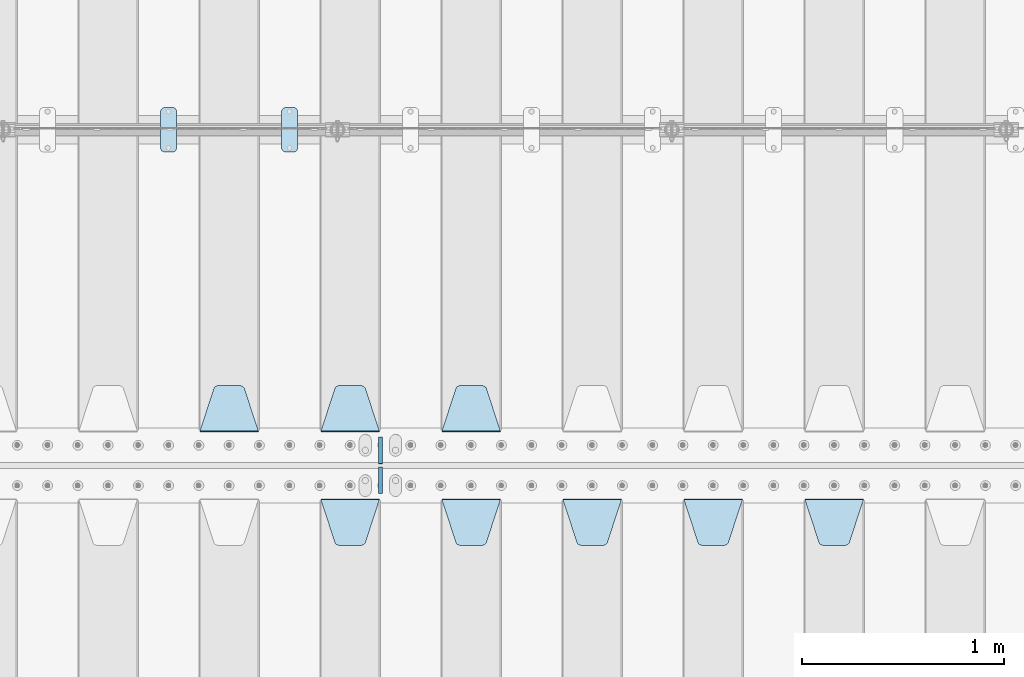
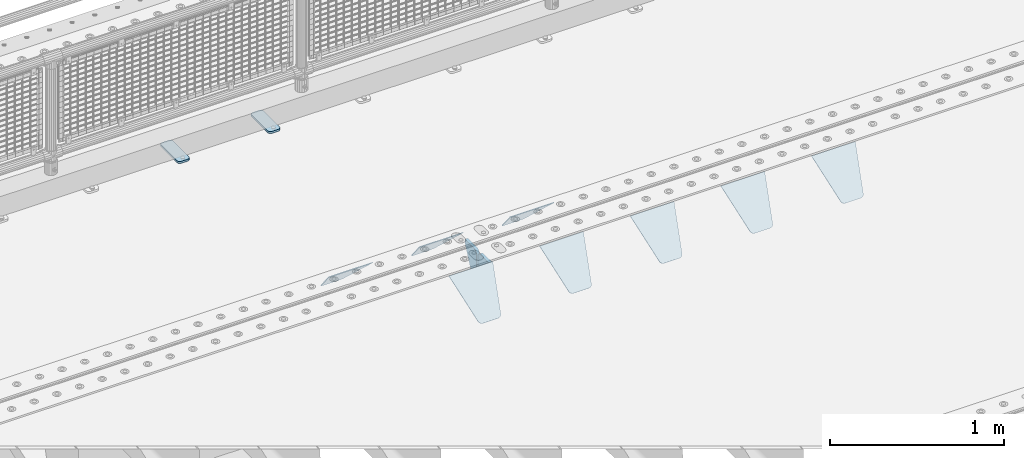
# One storey, part 212 of 240: 12 plates.
"""IFC2X3 building model written with IfcOpenShell, lengths in millimetres."""

from ifc_helpers import new_model, si_unit, frame, origin_with_axes, place, context, subcontext, project, spatial, faceted_brep, material, type_object, element, save


model = new_model("IFC2X3")

# Units and contexts
model_context = context("Model", 3, precision=1e-05, world=origin_with_axes())
body_context = subcontext(model_context, "Body", "Model", "MODEL_VIEW")
ifc_project = project(units=[si_unit("LENGTHUNIT", "METRE", prefix="MILLI"), si_unit("AREAUNIT", "SQUARE_METRE"), si_unit("VOLUMEUNIT", "CUBIC_METRE"), si_unit("MASSUNIT", "GRAM", prefix="KILO"), si_unit("TIMEUNIT", "SECOND"), si_unit("PLANEANGLEUNIT", "RADIAN"), si_unit("SOLIDANGLEUNIT", "STERADIAN"), si_unit("THERMODYNAMICTEMPERATUREUNIT", "DEGREE_CELSIUS"), si_unit("LUMINOUSINTENSITYUNIT", "LUMEN")], contexts=[model_context])

# Site, building, storey
site_placement = place(None, origin_with_axes())
site = spatial("IfcSite", under=ifc_project, at=site_placement, CompositionType="ELEMENT")
building_placement = place(site_placement, origin_with_axes())
building = spatial("IfcBuilding", under=site, at=building_placement, Name="Standard", CompositionType="ELEMENT")
storey_placement = place(building_placement, origin_with_axes())
storey = spatial("IfcBuildingStorey", under=building, at=storey_placement, Name="Undefined", CompositionType="ELEMENT", Elevation=0.0)

# Plates
ifc_material_1 = material(Name="STEEL/S355N")
plate_type_1 = type_object("IfcPlateType", PredefinedType="NOTDEFINED")
plate_1_placement = place(storey_placement, frame((48705.0, 32831.767766956, -1.76776695296758), z_axis=(0.0, -0.707106781186547, -0.707106781186548), x_axis=(1.0, 0.0, 0.0)))
element("IfcPlate", 1, at=plate_1_placement, inside=storey, type_object=plate_type_1, material=ifc_material_1, context=body_context, shape_type="Brep", body=[
    faceted_brep([(0.0, -2.5, 0.0), (69.345504679477, -2.50000000000364, 300.171731424827), (69.345504679477, 2.49999999999636, 300.171731424827), (0.0, 2.5, 0.0), (70.927406119954, -2.50000000000364, 304.897442415397), (70.927406119954, 2.49999999999636, 304.897442415397), (73.3818627772271, -2.50000000000728, 309.234538108525), (73.3818627772271, 2.49999999999636, 309.234538108529), (76.6187032999587, -2.50000000000728, 313.023683126099), (76.6187032999587, 2.49999999999636, 313.023683126103), (80.5190132705029, -2.50000000000364, 316.125672595368), (80.5190132705029, 2.49999999999636, 316.125672595368), (84.9395038596849, -2.50000000000364, 318.426546230472), (84.9395038596849, 2.49999999999636, 318.426546230472), (89.7177759439219, -2.5, 319.841774983277), (89.7177759439219, 2.49999999999636, 319.841774983273), (94.6782862926484, -2.50000000000364, 320.319366455074), (94.6782862926484, 2.49999999999636, 320.319366455074), (195.321713707352, -2.50000000000364, 320.319366455074), (195.321713707352, 2.49999999999636, 320.319366455074), (200.282224056078, -2.50000000000364, 319.841774983273), (200.282224056078, 2.49999999999636, 319.841774983273), (205.060496140315, -2.50000000000364, 318.426546230472), (205.060496140315, 2.49999999999636, 318.426546230472), (209.480986729497, -2.50000000000364, 316.125672595368), (209.480986729497, 2.49999999999636, 316.125672595368), (213.381296700041, -2.50000000000728, 313.023683126099), (213.381296700041, 2.49999999999272, 313.023683126099), (216.618137222766, -2.50000000000364, 309.234538108522), (216.618137222766, 2.49999999999636, 309.234538108522), (219.072593880039, -2.50000000000364, 304.897442415397), (219.072593880039, 2.49999999999636, 304.897442415397), (220.654495320523, -2.50000000000364, 300.171731424827), (220.654495320523, 2.49999999999636, 300.171731424827), (290.0, -2.50000000000364, -3.63797880709171e-12), (290.0, 2.49999999999636, -3.63797880709171e-12)], [[[0, 1, 2, 3]], [[1, 4, 5, 2]], [[4, 6, 7, 5]], [[6, 8, 9, 7]], [[8, 10, 11, 9]], [[10, 12, 13, 11]], [[12, 14, 15, 13]], [[14, 16, 17, 15]], [[16, 18, 19, 17]], [[18, 20, 21, 19]], [[20, 22, 23, 21]], [[22, 24, 25, 23]], [[24, 26, 27, 25]], [[26, 28, 29, 27]], [[28, 30, 31, 29]], [[30, 32, 33, 31]], [[32, 34, 35, 33]], [[34, 0, 3, 35]], [[5, 7, 9, 11, 13, 15, 17, 19, 21, 23, 25, 27, 29, 31, 33, 35, 3, 2]], [[34, 32, 30, 28, 26, 24, 22, 20, 18, 16, 14, 12, 10, 8, 6, 4, 1, 0]]]),
])
plate_2_placement = place(storey_placement, frame((48105.0, 32831.767766956, -1.76776695296758), z_axis=(0.0, -0.707106781186547, -0.707106781186548), x_axis=(1.0, 0.0, 0.0)))
element("IfcPlate", 2, at=plate_2_placement, inside=storey, type_object=plate_type_1, material=ifc_material_1, context=body_context, shape_type="Brep", body=[
    faceted_brep([(0.0, -2.5, 0.0), (69.345504679477, -2.50000000000364, 300.171731424827), (69.345504679477, 2.49999999999636, 300.171731424827), (0.0, 2.5, 0.0), (70.927406119954, -2.50000000000364, 304.897442415397), (70.927406119954, 2.49999999999636, 304.897442415397), (73.3818627772271, -2.50000000000728, 309.234538108525), (73.3818627772271, 2.49999999999636, 309.234538108529), (76.6187032999587, -2.50000000000728, 313.023683126099), (76.6187032999587, 2.49999999999636, 313.023683126103), (80.5190132705029, -2.50000000000364, 316.125672595368), (80.5190132705029, 2.49999999999636, 316.125672595368), (84.9395038596849, -2.50000000000364, 318.426546230472), (84.9395038596849, 2.49999999999636, 318.426546230472), (89.7177759439219, -2.5, 319.841774983277), (89.7177759439219, 2.49999999999636, 319.841774983273), (94.6782862926484, -2.50000000000364, 320.319366455074), (94.6782862926484, 2.49999999999636, 320.319366455074), (195.321713707352, -2.50000000000364, 320.319366455074), (195.321713707352, 2.49999999999636, 320.319366455074), (200.282224056078, -2.50000000000364, 319.841774983273), (200.282224056078, 2.49999999999636, 319.841774983273), (205.060496140315, -2.50000000000364, 318.426546230472), (205.060496140315, 2.49999999999636, 318.426546230472), (209.480986729497, -2.50000000000364, 316.125672595368), (209.480986729497, 2.49999999999636, 316.125672595368), (213.381296700041, -2.50000000000728, 313.023683126099), (213.381296700041, 2.49999999999272, 313.023683126099), (216.618137222766, -2.50000000000364, 309.234538108522), (216.618137222766, 2.49999999999636, 309.234538108522), (219.072593880039, -2.50000000000364, 304.897442415397), (219.072593880039, 2.49999999999636, 304.897442415397), (220.654495320523, -2.50000000000364, 300.171731424827), (220.654495320523, 2.49999999999636, 300.171731424827), (290.0, -2.50000000000364, -3.63797880709171e-12), (290.0, 2.49999999999636, -3.63797880709171e-12)], [[[0, 1, 2, 3]], [[1, 4, 5, 2]], [[4, 6, 7, 5]], [[6, 8, 9, 7]], [[8, 10, 11, 9]], [[10, 12, 13, 11]], [[12, 14, 15, 13]], [[14, 16, 17, 15]], [[16, 18, 19, 17]], [[18, 20, 21, 19]], [[20, 22, 23, 21]], [[22, 24, 25, 23]], [[24, 26, 27, 25]], [[26, 28, 29, 27]], [[28, 30, 31, 29]], [[30, 32, 33, 31]], [[32, 34, 35, 33]], [[34, 0, 3, 35]], [[5, 7, 9, 11, 13, 15, 17, 19, 21, 23, 25, 27, 29, 31, 33, 35, 3, 2]], [[34, 32, 30, 28, 26, 24, 22, 20, 18, 16, 14, 12, 10, 8, 6, 4, 1, 0]]]),
])
plate_3_placement = place(storey_placement, frame((47505.0, 32831.767766956, -1.76776695296758), z_axis=(0.0, -0.707106781186547, -0.707106781186548), x_axis=(1.0, 0.0, 0.0)))
element("IfcPlate", 3, at=plate_3_placement, inside=storey, type_object=plate_type_1, material=ifc_material_1, context=body_context, shape_type="Brep", body=[
    faceted_brep([(0.0, -2.5, 0.0), (69.345504679477, -2.50000000000364, 300.171731424827), (69.345504679477, 2.49999999999636, 300.171731424827), (0.0, 2.5, 0.0), (70.927406119954, -2.50000000000364, 304.897442415397), (70.927406119954, 2.49999999999636, 304.897442415397), (73.3818627772271, -2.50000000000728, 309.234538108525), (73.3818627772271, 2.49999999999636, 309.234538108529), (76.6187032999587, -2.50000000000728, 313.023683126099), (76.6187032999587, 2.49999999999636, 313.023683126103), (80.5190132705029, -2.50000000000364, 316.125672595368), (80.5190132705029, 2.49999999999636, 316.125672595368), (84.9395038596849, -2.50000000000364, 318.426546230472), (84.9395038596849, 2.49999999999636, 318.426546230472), (89.7177759439219, -2.5, 319.841774983277), (89.7177759439219, 2.49999999999636, 319.841774983273), (94.6782862926484, -2.50000000000364, 320.319366455074), (94.6782862926484, 2.49999999999636, 320.319366455074), (195.321713707352, -2.50000000000364, 320.319366455074), (195.321713707352, 2.49999999999636, 320.319366455074), (200.282224056078, -2.50000000000364, 319.841774983273), (200.282224056078, 2.49999999999636, 319.841774983273), (205.060496140315, -2.50000000000364, 318.426546230472), (205.060496140315, 2.49999999999636, 318.426546230472), (209.480986729497, -2.50000000000364, 316.125672595368), (209.480986729497, 2.49999999999636, 316.125672595368), (213.381296700041, -2.50000000000728, 313.023683126099), (213.381296700041, 2.49999999999272, 313.023683126099), (216.618137222766, -2.50000000000364, 309.234538108522), (216.618137222766, 2.49999999999636, 309.234538108522), (219.072593880039, -2.50000000000364, 304.897442415397), (219.072593880039, 2.49999999999636, 304.897442415397), (220.654495320523, -2.50000000000364, 300.171731424827), (220.654495320523, 2.49999999999636, 300.171731424827), (290.0, -2.50000000000364, -3.63797880709171e-12), (290.0, 2.49999999999636, -3.63797880709171e-12)], [[[0, 1, 2, 3]], [[1, 4, 5, 2]], [[4, 6, 7, 5]], [[6, 8, 9, 7]], [[8, 10, 11, 9]], [[10, 12, 13, 11]], [[12, 14, 15, 13]], [[14, 16, 17, 15]], [[16, 18, 19, 17]], [[18, 20, 21, 19]], [[20, 22, 23, 21]], [[22, 24, 25, 23]], [[24, 26, 27, 25]], [[26, 28, 29, 27]], [[28, 30, 31, 29]], [[30, 32, 33, 31]], [[32, 34, 35, 33]], [[34, 0, 3, 35]], [[5, 7, 9, 11, 13, 15, 17, 19, 21, 23, 25, 27, 29, 31, 33, 35, 3, 2]], [[34, 32, 30, 28, 26, 24, 22, 20, 18, 16, 14, 12, 10, 8, 6, 4, 1, 0]]]),
])
plate_4_placement = place(storey_placement, frame((46905.0, 32831.767766956, -1.76776695296758), z_axis=(0.0, -0.707106781186547, -0.707106781186548), x_axis=(1.0, 0.0, 0.0)))
element("IfcPlate", 4, at=plate_4_placement, inside=storey, type_object=plate_type_1, material=ifc_material_1, context=body_context, shape_type="Brep", body=[
    faceted_brep([(0.0, -2.5, 0.0), (69.345504679477, -2.50000000000364, 300.171731424827), (69.345504679477, 2.49999999999636, 300.171731424827), (0.0, 2.5, 0.0), (70.927406119954, -2.50000000000364, 304.897442415397), (70.927406119954, 2.49999999999636, 304.897442415397), (73.3818627772271, -2.50000000000728, 309.234538108525), (73.3818627772271, 2.49999999999636, 309.234538108529), (76.6187032999587, -2.50000000000728, 313.023683126099), (76.6187032999587, 2.49999999999636, 313.023683126103), (80.5190132705029, -2.50000000000364, 316.125672595368), (80.5190132705029, 2.49999999999636, 316.125672595368), (84.9395038596849, -2.50000000000364, 318.426546230472), (84.9395038596849, 2.49999999999636, 318.426546230472), (89.7177759439219, -2.5, 319.841774983277), (89.7177759439219, 2.49999999999636, 319.841774983273), (94.6782862926484, -2.50000000000364, 320.319366455074), (94.6782862926484, 2.49999999999636, 320.319366455074), (195.321713707352, -2.50000000000364, 320.319366455074), (195.321713707352, 2.49999999999636, 320.319366455074), (200.282224056078, -2.50000000000364, 319.841774983273), (200.282224056078, 2.49999999999636, 319.841774983273), (205.060496140315, -2.50000000000364, 318.426546230472), (205.060496140315, 2.49999999999636, 318.426546230472), (209.480986729497, -2.50000000000364, 316.125672595368), (209.480986729497, 2.49999999999636, 316.125672595368), (213.381296700041, -2.50000000000728, 313.023683126099), (213.381296700041, 2.49999999999272, 313.023683126099), (216.618137222766, -2.50000000000364, 309.234538108522), (216.618137222766, 2.49999999999636, 309.234538108522), (219.072593880039, -2.50000000000364, 304.897442415397), (219.072593880039, 2.49999999999636, 304.897442415397), (220.654495320523, -2.50000000000364, 300.171731424827), (220.654495320523, 2.49999999999636, 300.171731424827), (290.0, -2.50000000000364, -3.63797880709171e-12), (290.0, 2.49999999999636, -3.63797880709171e-12)], [[[0, 1, 2, 3]], [[1, 4, 5, 2]], [[4, 6, 7, 5]], [[6, 8, 9, 7]], [[8, 10, 11, 9]], [[10, 12, 13, 11]], [[12, 14, 15, 13]], [[14, 16, 17, 15]], [[16, 18, 19, 17]], [[18, 20, 21, 19]], [[20, 22, 23, 21]], [[22, 24, 25, 23]], [[24, 26, 27, 25]], [[26, 28, 29, 27]], [[28, 30, 31, 29]], [[30, 32, 33, 31]], [[32, 34, 35, 33]], [[34, 0, 3, 35]], [[5, 7, 9, 11, 13, 15, 17, 19, 21, 23, 25, 27, 29, 31, 33, 35, 3, 2]], [[34, 32, 30, 28, 26, 24, 22, 20, 18, 16, 14, 12, 10, 8, 6, 4, 1, 0]]]),
])
plate_5_placement = place(storey_placement, frame((46305.0, 32831.767766956, -1.76776695296758), z_axis=(0.0, -0.707106781186547, -0.707106781186548), x_axis=(1.0, 0.0, 0.0)))
element("IfcPlate", 5, at=plate_5_placement, inside=storey, type_object=plate_type_1, material=ifc_material_1, context=body_context, shape_type="Brep", body=[
    faceted_brep([(0.0, -2.5, 0.0), (69.345504679477, -2.50000000000364, 300.171731424827), (69.345504679477, 2.49999999999636, 300.171731424827), (0.0, 2.5, 0.0), (70.927406119954, -2.50000000000364, 304.897442415397), (70.927406119954, 2.49999999999636, 304.897442415397), (73.3818627772271, -2.50000000000728, 309.234538108525), (73.3818627772271, 2.49999999999636, 309.234538108529), (76.6187032999587, -2.50000000000728, 313.023683126099), (76.6187032999587, 2.49999999999636, 313.023683126103), (80.5190132705029, -2.50000000000364, 316.125672595368), (80.5190132705029, 2.49999999999636, 316.125672595368), (84.9395038596849, -2.50000000000364, 318.426546230472), (84.9395038596849, 2.49999999999636, 318.426546230472), (89.7177759439219, -2.5, 319.841774983277), (89.7177759439219, 2.49999999999636, 319.841774983273), (94.6782862926484, -2.50000000000364, 320.319366455074), (94.6782862926484, 2.49999999999636, 320.319366455074), (195.321713707352, -2.50000000000364, 320.319366455074), (195.321713707352, 2.49999999999636, 320.319366455074), (200.282224056078, -2.50000000000364, 319.841774983273), (200.282224056078, 2.49999999999636, 319.841774983273), (205.060496140315, -2.50000000000364, 318.426546230472), (205.060496140315, 2.49999999999636, 318.426546230472), (209.480986729497, -2.50000000000364, 316.125672595368), (209.480986729497, 2.49999999999636, 316.125672595368), (213.381296700041, -2.50000000000728, 313.023683126099), (213.381296700041, 2.49999999999272, 313.023683126099), (216.618137222766, -2.50000000000364, 309.234538108522), (216.618137222766, 2.49999999999636, 309.234538108522), (219.072593880039, -2.50000000000364, 304.897442415397), (219.072593880039, 2.49999999999636, 304.897442415397), (220.654495320523, -2.50000000000364, 300.171731424827), (220.654495320523, 2.49999999999636, 300.171731424827), (290.0, -2.50000000000364, -3.63797880709171e-12), (290.0, 2.49999999999636, -3.63797880709171e-12)], [[[0, 1, 2, 3]], [[1, 4, 5, 2]], [[4, 6, 7, 5]], [[6, 8, 9, 7]], [[8, 10, 11, 9]], [[10, 12, 13, 11]], [[12, 14, 15, 13]], [[14, 16, 17, 15]], [[16, 18, 19, 17]], [[18, 20, 21, 19]], [[20, 22, 23, 21]], [[22, 24, 25, 23]], [[24, 26, 27, 25]], [[26, 28, 29, 27]], [[28, 30, 31, 29]], [[30, 32, 33, 31]], [[32, 34, 35, 33]], [[34, 0, 3, 35]], [[5, 7, 9, 11, 13, 15, 17, 19, 21, 23, 25, 27, 29, 31, 33, 35, 3, 2]], [[34, 32, 30, 28, 26, 24, 22, 20, 18, 16, 14, 12, 10, 8, 6, 4, 1, 0]]]),
])
plate_6_placement = place(storey_placement, frame((47195.0, 33168.232233047, -1.76776695296758), z_axis=(0.0, 0.707106781186547, -0.707106781186548), x_axis=(-1.0, 0.0, 0.0)))
element("IfcPlate", 6, at=plate_6_placement, inside=storey, type_object=plate_type_1, material=ifc_material_1, context=body_context, shape_type="Brep", body=[
    faceted_brep([(0.0, -2.5, 0.0), (69.345504679477, -2.50000000000364, 300.171731424827), (69.345504679477, 2.49999999999636, 300.171731424827), (0.0, 2.5, 0.0), (70.927406119954, -2.50000000000364, 304.897442415397), (70.927406119954, 2.49999999999636, 304.897442415397), (73.3818627772271, -2.50000000000728, 309.234538108525), (73.3818627772271, 2.49999999999636, 309.234538108529), (76.6187032999587, -2.50000000000728, 313.023683126099), (76.6187032999587, 2.49999999999636, 313.023683126103), (80.5190132705029, -2.50000000000364, 316.125672595368), (80.5190132705029, 2.49999999999636, 316.125672595368), (84.9395038596849, -2.50000000000364, 318.426546230472), (84.9395038596849, 2.49999999999636, 318.426546230472), (89.7177759439219, -2.5, 319.841774983277), (89.7177759439219, 2.49999999999636, 319.841774983273), (94.6782862926484, -2.50000000000364, 320.319366455074), (94.6782862926484, 2.49999999999636, 320.319366455074), (195.321713707352, -2.50000000000364, 320.319366455074), (195.321713707352, 2.49999999999636, 320.319366455074), (200.282224056078, -2.50000000000364, 319.841774983273), (200.282224056078, 2.49999999999636, 319.841774983273), (205.060496140315, -2.50000000000364, 318.426546230472), (205.060496140315, 2.49999999999636, 318.426546230472), (209.480986729497, -2.50000000000364, 316.125672595368), (209.480986729497, 2.49999999999636, 316.125672595368), (213.381296700041, -2.50000000000728, 313.023683126099), (213.381296700041, 2.49999999999272, 313.023683126099), (216.618137222766, -2.50000000000364, 309.234538108522), (216.618137222766, 2.49999999999636, 309.234538108522), (219.072593880039, -2.50000000000364, 304.897442415397), (219.072593880039, 2.49999999999636, 304.897442415397), (220.654495320523, -2.50000000000364, 300.171731424827), (220.654495320523, 2.49999999999636, 300.171731424827), (290.0, -2.50000000000364, -3.63797880709171e-12), (290.0, 2.49999999999636, -3.63797880709171e-12)], [[[0, 1, 2, 3]], [[1, 4, 5, 2]], [[4, 6, 7, 5]], [[6, 8, 9, 7]], [[8, 10, 11, 9]], [[10, 12, 13, 11]], [[12, 14, 15, 13]], [[14, 16, 17, 15]], [[16, 18, 19, 17]], [[18, 20, 21, 19]], [[20, 22, 23, 21]], [[22, 24, 25, 23]], [[24, 26, 27, 25]], [[26, 28, 29, 27]], [[28, 30, 31, 29]], [[30, 32, 33, 31]], [[32, 34, 35, 33]], [[34, 0, 3, 35]], [[5, 7, 9, 11, 13, 15, 17, 19, 21, 23, 25, 27, 29, 31, 33, 35, 3, 2]], [[34, 32, 30, 28, 26, 24, 22, 20, 18, 16, 14, 12, 10, 8, 6, 4, 1, 0]]]),
])
plate_7_placement = place(storey_placement, frame((46595.0, 33168.232233047, -1.76776695296758), z_axis=(0.0, 0.707106781186547, -0.707106781186548), x_axis=(-1.0, 0.0, 0.0)))
element("IfcPlate", 7, at=plate_7_placement, inside=storey, type_object=plate_type_1, material=ifc_material_1, context=body_context, shape_type="Brep", body=[
    faceted_brep([(0.0, -2.5, 0.0), (69.345504679477, -2.50000000000364, 300.171731424827), (69.345504679477, 2.49999999999636, 300.171731424827), (0.0, 2.5, 0.0), (70.927406119954, -2.50000000000364, 304.897442415397), (70.927406119954, 2.49999999999636, 304.897442415397), (73.3818627772271, -2.50000000000728, 309.234538108525), (73.3818627772271, 2.49999999999636, 309.234538108529), (76.6187032999587, -2.50000000000728, 313.023683126099), (76.6187032999587, 2.49999999999636, 313.023683126103), (80.5190132705029, -2.50000000000364, 316.125672595368), (80.5190132705029, 2.49999999999636, 316.125672595368), (84.9395038596849, -2.50000000000364, 318.426546230472), (84.9395038596849, 2.49999999999636, 318.426546230472), (89.7177759439219, -2.5, 319.841774983277), (89.7177759439219, 2.49999999999636, 319.841774983273), (94.6782862926484, -2.50000000000364, 320.319366455074), (94.6782862926484, 2.49999999999636, 320.319366455074), (195.321713707352, -2.50000000000364, 320.319366455074), (195.321713707352, 2.49999999999636, 320.319366455074), (200.282224056078, -2.50000000000364, 319.841774983273), (200.282224056078, 2.49999999999636, 319.841774983273), (205.060496140315, -2.50000000000364, 318.426546230472), (205.060496140315, 2.49999999999636, 318.426546230472), (209.480986729497, -2.50000000000364, 316.125672595368), (209.480986729497, 2.49999999999636, 316.125672595368), (213.381296700041, -2.50000000000728, 313.023683126099), (213.381296700041, 2.49999999999272, 313.023683126099), (216.618137222766, -2.50000000000364, 309.234538108522), (216.618137222766, 2.49999999999636, 309.234538108522), (219.072593880039, -2.50000000000364, 304.897442415397), (219.072593880039, 2.49999999999636, 304.897442415397), (220.654495320523, -2.50000000000364, 300.171731424827), (220.654495320523, 2.49999999999636, 300.171731424827), (290.0, -2.50000000000364, -3.63797880709171e-12), (290.0, 2.49999999999636, -3.63797880709171e-12)], [[[0, 1, 2, 3]], [[1, 4, 5, 2]], [[4, 6, 7, 5]], [[6, 8, 9, 7]], [[8, 10, 11, 9]], [[10, 12, 13, 11]], [[12, 14, 15, 13]], [[14, 16, 17, 15]], [[16, 18, 19, 17]], [[18, 20, 21, 19]], [[20, 22, 23, 21]], [[22, 24, 25, 23]], [[24, 26, 27, 25]], [[26, 28, 29, 27]], [[28, 30, 31, 29]], [[30, 32, 33, 31]], [[32, 34, 35, 33]], [[34, 0, 3, 35]], [[5, 7, 9, 11, 13, 15, 17, 19, 21, 23, 25, 27, 29, 31, 33, 35, 3, 2]], [[34, 32, 30, 28, 26, 24, 22, 20, 18, 16, 14, 12, 10, 8, 6, 4, 1, 0]]]),
])
plate_8_placement = place(storey_placement, frame((45995.0, 33168.232233047, -1.76776695296758), z_axis=(0.0, 0.707106781186547, -0.707106781186548), x_axis=(-1.0, 0.0, 0.0)))
element("IfcPlate", 8, at=plate_8_placement, inside=storey, type_object=plate_type_1, material=ifc_material_1, context=body_context, shape_type="Brep", body=[
    faceted_brep([(0.0, -2.5, 0.0), (69.345504679477, -2.50000000000364, 300.171731424827), (69.345504679477, 2.49999999999636, 300.171731424827), (0.0, 2.5, 0.0), (70.927406119954, -2.50000000000364, 304.897442415397), (70.927406119954, 2.49999999999636, 304.897442415397), (73.3818627772271, -2.50000000000728, 309.234538108525), (73.3818627772271, 2.49999999999636, 309.234538108529), (76.6187032999587, -2.50000000000728, 313.023683126099), (76.6187032999587, 2.49999999999636, 313.023683126103), (80.5190132705029, -2.50000000000364, 316.125672595368), (80.5190132705029, 2.49999999999636, 316.125672595368), (84.9395038596849, -2.50000000000364, 318.426546230472), (84.9395038596849, 2.49999999999636, 318.426546230472), (89.7177759439219, -2.5, 319.841774983277), (89.7177759439219, 2.49999999999636, 319.841774983273), (94.6782862926484, -2.50000000000364, 320.319366455074), (94.6782862926484, 2.49999999999636, 320.319366455074), (195.321713707352, -2.50000000000364, 320.319366455074), (195.321713707352, 2.49999999999636, 320.319366455074), (200.282224056078, -2.50000000000364, 319.841774983273), (200.282224056078, 2.49999999999636, 319.841774983273), (205.060496140315, -2.50000000000364, 318.426546230472), (205.060496140315, 2.49999999999636, 318.426546230472), (209.480986729497, -2.50000000000364, 316.125672595368), (209.480986729497, 2.49999999999636, 316.125672595368), (213.381296700041, -2.50000000000728, 313.023683126099), (213.381296700041, 2.49999999999272, 313.023683126099), (216.618137222766, -2.50000000000364, 309.234538108522), (216.618137222766, 2.49999999999636, 309.234538108522), (219.072593880039, -2.50000000000364, 304.897442415397), (219.072593880039, 2.49999999999636, 304.897442415397), (220.654495320523, -2.50000000000364, 300.171731424827), (220.654495320523, 2.49999999999636, 300.171731424827), (290.0, -2.50000000000364, -3.63797880709171e-12), (290.0, 2.49999999999636, -3.63797880709171e-12)], [[[0, 1, 2, 3]], [[1, 4, 5, 2]], [[4, 6, 7, 5]], [[6, 8, 9, 7]], [[8, 10, 11, 9]], [[10, 12, 13, 11]], [[12, 14, 15, 13]], [[14, 16, 17, 15]], [[16, 18, 19, 17]], [[18, 20, 21, 19]], [[20, 22, 23, 21]], [[22, 24, 25, 23]], [[24, 26, 27, 25]], [[26, 28, 29, 27]], [[28, 30, 31, 29]], [[30, 32, 33, 31]], [[32, 34, 35, 33]], [[34, 0, 3, 35]], [[5, 7, 9, 11, 13, 15, 17, 19, 21, 23, 25, 27, 29, 31, 33, 35, 3, 2]], [[34, 32, 30, 28, 26, 24, 22, 20, 18, 16, 14, 12, 10, 8, 6, 4, 1, 0]]]),
])
ifc_material_2 = material(Name="STEEL/S355J2")
plate_type_2 = type_object("IfcPlateType", PredefinedType="NOTDEFINED")
plate_9_placement = place(storey_placement, frame((46110.0, 34774.5, 21.0199999999977), z_axis=(1.0, 0.0, 0.0), x_axis=(0.0, -1.0, 0.0)))
element("IfcPlate", 9, at=plate_9_placement, inside=storey, type_object=plate_type_2, material=ifc_material_2, context=body_context, shape_type="Brep", body=[
    faceted_brep([(0.0, -7.0, 20.0), (0.0, -7.0, 60.0), (0.0, 7.0, 60.0), (0.0, 7.0, 20.0), (0.384294391937146, -7.0, 63.9018064403208), (0.384294391937146, 7.0, 63.9018064403208), (1.52240934977453, -7.0, 67.6536686473046), (1.52240934977453, 7.0, 67.6536686473046), (3.37060775394639, -7.0, 71.1114046603907), (3.37060775394639, 7.0, 71.1114046603907), (5.85786437626666, -7.0, 74.1421356237333), (5.85786437626666, 7.0, 74.1421356237333), (8.88859533960931, -7.0, 76.6293922460536), (8.88859533960931, 7.0, 76.6293922460536), (12.3463313526954, -7.0, 78.4775906502255), (12.3463313526954, 7.0, 78.4775906502255), (16.0981935596792, -7.0, 79.6157056080629), (16.0981935596792, 7.0, 79.6157056080629), (20.0, -7.0, 80.0), (20.0, 7.0, 80.0), (200.0, -7.0, 80.0), (200.0, 7.0, 80.0), (203.901806440321, -7.0, 79.6157056080629), (203.901806440321, 7.0, 79.6157056080629), (207.653668647305, -7.0, 78.4775906502255), (207.653668647305, 7.0, 78.4775906502255), (211.111404660391, -7.0, 76.6293922460536), (211.111404660391, 7.0, 76.6293922460536), (214.142135623733, -7.0, 74.1421356237333), (214.142135623733, 7.0, 74.1421356237333), (216.629392246054, -7.0, 71.1114046603907), (216.629392246054, 7.0, 71.1114046603907), (218.477590650225, -7.0, 67.6536686473046), (218.477590650225, 7.0, 67.6536686473046), (219.615705608063, -7.0, 63.9018064403208), (219.615705608063, 7.0, 63.9018064403208), (220.0, -7.0, 60.0), (220.0, 7.0, 60.0), (220.0, -7.0, 20.0), (220.0, 7.0, 20.0), (219.615705608063, -7.0, 16.0981935596792), (219.615705608063, 7.0, 16.0981935596792), (218.477590650225, -7.0, 12.3463313526954), (218.477590650225, 7.0, 12.3463313526954), (216.629392246054, -7.0, 8.88859533960931), (216.629392246054, 7.0, 8.88859533960931), (214.142135623733, -7.0, 5.85786437626666), (214.142135623733, 7.0, 5.85786437626666), (211.111404660391, -7.0, 3.37060775394639), (211.111404660391, 7.0, 3.37060775394639), (207.653668647305, -7.0, 1.52240934977453), (207.653668647305, 7.0, 1.52240934977453), (203.901806440321, -7.0, 0.384294391937146), (203.901806440321, 7.0, 0.384294391937146), (200.0, -7.0, 0.0), (200.0, 7.0, 0.0), (20.0, -7.0, 0.0), (20.0, 7.0, 0.0), (16.0981935596792, -7.0, 0.384294391937146), (16.0981935596792, 7.0, 0.384294391937146), (12.3463313526954, -7.0, 1.52240934977453), (12.3463313526954, 7.0, 1.52240934977453), (8.88859533960931, -7.0, 3.37060775394639), (8.88859533960931, 7.0, 3.37060775394639), (5.85786437626666, -7.0, 5.85786437626666), (5.85786437626666, 7.0, 5.85786437626666), (3.37060775394639, -7.0, 8.88859533960931), (3.37060775394639, 7.0, 8.88859533960931), (1.52240934977453, -7.0, 12.3463313526954), (1.52240934977453, 7.0, 12.3463313526954), (0.384294391937146, -7.0, 16.0981935596792), (0.384294391937146, 7.0, 16.0981935596792)], [[[0, 1, 2, 3]], [[1, 4, 5, 2]], [[4, 6, 7, 5]], [[6, 8, 9, 7]], [[8, 10, 11, 9]], [[10, 12, 13, 11]], [[12, 14, 15, 13]], [[14, 16, 17, 15]], [[16, 18, 19, 17]], [[18, 20, 21, 19]], [[20, 22, 23, 21]], [[22, 24, 25, 23]], [[24, 26, 27, 25]], [[26, 28, 29, 27]], [[28, 30, 31, 29]], [[30, 32, 33, 31]], [[32, 34, 35, 33]], [[34, 36, 37, 35]], [[36, 38, 39, 37]], [[38, 40, 41, 39]], [[40, 42, 43, 41]], [[42, 44, 45, 43]], [[44, 46, 47, 45]], [[46, 48, 49, 47]], [[48, 50, 51, 49]], [[50, 52, 53, 51]], [[52, 54, 55, 53]], [[54, 56, 57, 55]], [[56, 58, 59, 57]], [[58, 60, 61, 59]], [[60, 62, 63, 61]], [[62, 64, 65, 63]], [[64, 66, 67, 65]], [[66, 68, 69, 67]], [[68, 70, 71, 69]], [[70, 0, 3, 71]], [[5, 7, 9, 11, 13, 15, 17, 19, 21, 23, 25, 27, 29, 31, 33, 35, 37, 39, 41, 43, 45, 47, 49, 51, 53, 55, 57, 59, 61, 63, 65, 67, 69, 71, 3, 2]], [[70, 68, 66, 64, 62, 60, 58, 56, 54, 52, 50, 48, 46, 44, 42, 40, 38, 36, 34, 32, 30, 28, 26, 24, 22, 20, 18, 16, 14, 12, 10, 8, 6, 4, 1, 0]]]),
])
plate_10_placement = place(storey_placement, frame((45510.0, 34774.5, 21.0199999999977), z_axis=(1.0, 0.0, 0.0), x_axis=(0.0, -1.0, 0.0)))
element("IfcPlate", 10, at=plate_10_placement, inside=storey, type_object=plate_type_2, material=ifc_material_2, context=body_context, shape_type="Brep", body=[
    faceted_brep([(0.0, -7.0, 20.0), (0.0, -7.0, 60.0), (0.0, 7.0, 60.0), (0.0, 7.0, 20.0), (0.384294391937146, -7.0, 63.9018064403208), (0.384294391937146, 7.0, 63.9018064403208), (1.52240934977453, -7.0, 67.6536686473046), (1.52240934977453, 7.0, 67.6536686473046), (3.37060775394639, -7.0, 71.1114046603907), (3.37060775394639, 7.0, 71.1114046603907), (5.85786437626666, -7.0, 74.1421356237333), (5.85786437626666, 7.0, 74.1421356237333), (8.88859533960931, -7.0, 76.6293922460536), (8.88859533960931, 7.0, 76.6293922460536), (12.3463313526954, -7.0, 78.4775906502255), (12.3463313526954, 7.0, 78.4775906502255), (16.0981935596792, -7.0, 79.6157056080629), (16.0981935596792, 7.0, 79.6157056080629), (20.0, -7.0, 80.0), (20.0, 7.0, 80.0), (200.0, -7.0, 80.0), (200.0, 7.0, 80.0), (203.901806440321, -7.0, 79.6157056080629), (203.901806440321, 7.0, 79.6157056080629), (207.653668647305, -7.0, 78.4775906502255), (207.653668647305, 7.0, 78.4775906502255), (211.111404660391, -7.0, 76.6293922460536), (211.111404660391, 7.0, 76.6293922460536), (214.142135623733, -7.0, 74.1421356237333), (214.142135623733, 7.0, 74.1421356237333), (216.629392246054, -7.0, 71.1114046603907), (216.629392246054, 7.0, 71.1114046603907), (218.477590650225, -7.0, 67.6536686473046), (218.477590650225, 7.0, 67.6536686473046), (219.615705608063, -7.0, 63.9018064403208), (219.615705608063, 7.0, 63.9018064403208), (220.0, -7.0, 60.0), (220.0, 7.0, 60.0), (220.0, -7.0, 20.0), (220.0, 7.0, 20.0), (219.615705608063, -7.0, 16.0981935596792), (219.615705608063, 7.0, 16.0981935596792), (218.477590650225, -7.0, 12.3463313526954), (218.477590650225, 7.0, 12.3463313526954), (216.629392246054, -7.0, 8.88859533960931), (216.629392246054, 7.0, 8.88859533960931), (214.142135623733, -7.0, 5.85786437626666), (214.142135623733, 7.0, 5.85786437626666), (211.111404660391, -7.0, 3.37060775394639), (211.111404660391, 7.0, 3.37060775394639), (207.653668647305, -7.0, 1.52240934977453), (207.653668647305, 7.0, 1.52240934977453), (203.901806440321, -7.0, 0.384294391937146), (203.901806440321, 7.0, 0.384294391937146), (200.0, -7.0, 0.0), (200.0, 7.0, 0.0), (20.0, -7.0, 0.0), (20.0, 7.0, 0.0), (16.0981935596792, -7.0, 0.384294391937146), (16.0981935596792, 7.0, 0.384294391937146), (12.3463313526954, -7.0, 1.52240934977453), (12.3463313526954, 7.0, 1.52240934977453), (8.88859533960931, -7.0, 3.37060775394639), (8.88859533960931, 7.0, 3.37060775394639), (5.85786437626666, -7.0, 5.85786437626666), (5.85786437626666, 7.0, 5.85786437626666), (3.37060775394639, -7.0, 8.88859533960931), (3.37060775394639, 7.0, 8.88859533960931), (1.52240934977453, -7.0, 12.3463313526954), (1.52240934977453, 7.0, 12.3463313526954), (0.384294391937146, -7.0, 16.0981935596792), (0.384294391937146, 7.0, 16.0981935596792)], [[[0, 1, 2, 3]], [[1, 4, 5, 2]], [[4, 6, 7, 5]], [[6, 8, 9, 7]], [[8, 10, 11, 9]], [[10, 12, 13, 11]], [[12, 14, 15, 13]], [[14, 16, 17, 15]], [[16, 18, 19, 17]], [[18, 20, 21, 19]], [[20, 22, 23, 21]], [[22, 24, 25, 23]], [[24, 26, 27, 25]], [[26, 28, 29, 27]], [[28, 30, 31, 29]], [[30, 32, 33, 31]], [[32, 34, 35, 33]], [[34, 36, 37, 35]], [[36, 38, 39, 37]], [[38, 40, 41, 39]], [[40, 42, 43, 41]], [[42, 44, 45, 43]], [[44, 46, 47, 45]], [[46, 48, 49, 47]], [[48, 50, 51, 49]], [[50, 52, 53, 51]], [[52, 54, 55, 53]], [[54, 56, 57, 55]], [[56, 58, 59, 57]], [[58, 60, 61, 59]], [[60, 62, 63, 61]], [[62, 64, 65, 63]], [[64, 66, 67, 65]], [[66, 68, 69, 67]], [[68, 70, 71, 69]], [[70, 0, 3, 71]], [[5, 7, 9, 11, 13, 15, 17, 19, 21, 23, 25, 27, 29, 31, 33, 35, 37, 39, 41, 43, 45, 47, 49, 51, 53, 55, 57, 59, 61, 63, 65, 67, 69, 71, 3, 2]], [[70, 68, 66, 64, 62, 60, 58, 56, 54, 52, 50, 48, 46, 44, 42, 40, 38, 36, 34, 32, 30, 28, 26, 24, 22, 20, 18, 16, 14, 12, 10, 8, 6, 4, 1, 0]]]),
])
plate_type_3 = type_object("IfcPlateType", PredefinedType="NOTDEFINED")
for number, where, z_axis, x_axis in (
    (11, (46600.0, 32860.0, -30.0), (0.0, 0.0, -1.0), (0.0, 1.0, 0.0)),
    (12, (46600.0, 33140.0, -30.0), (0.0, 0.0, -1.0), (0.0, -1.0, 0.0)),
):
    element("IfcPlate", number, at=place(storey_placement, frame(where, z_axis=z_axis, x_axis=x_axis)), inside=storey, type_object=plate_type_3, material=ifc_material_1, context=body_context, shape_type="Brep", body=[
        faceted_brep([(0.0, -10.0, 0.0), (0.0, -10.0, 30.0), (0.0, 10.0, 30.0), (0.0, 10.0, 0.0), (102.0, -10.0, 250.0), (102.0, 10.0, 250.0), (132.0, -10.0, 250.0), (132.0, 10.0, 250.0), (132.0, -10.0, 30.0), (132.0, 10.0, 30.0), (131.544232590368, -10.0, 24.790554669992), (131.544232590368, 10.0, 24.790554669992), (130.190778623579, -10.0, 19.7393957002299), (130.190778623579, 10.0, 19.7393957002299), (127.980762113533, -10.0, 15.0), (127.980762113533, 10.0, 15.0), (124.98133329357, -10.0, 10.7163717094038), (124.98133329357, 10.0, 10.7163717094038), (121.283628290596, -10.0, 7.01866670643062), (121.283628290596, 10.0, 7.01866670643062), (117.0, -10.0, 4.01923788646684), (117.0, 10.0, 4.01923788646684), (112.260604299769, -10.0, 1.80922137642278), (112.260604299769, 10.0, 1.80922137642278), (107.209445330009, -10.0, 0.455767409633722), (107.209445330009, 10.0, 0.455767409633722), (102.0, -10.0, 0.0), (102.0, 10.0, 0.0)], [[[0, 1, 2, 3]], [[1, 4, 5, 2]], [[4, 6, 7, 5]], [[6, 8, 9, 7]], [[8, 10, 11, 9]], [[10, 12, 13, 11]], [[12, 14, 15, 13]], [[14, 16, 17, 15]], [[16, 18, 19, 17]], [[18, 20, 21, 19]], [[20, 22, 23, 21]], [[22, 24, 25, 23]], [[24, 26, 27, 25]], [[26, 0, 3, 27]], [[5, 7, 9, 11, 13, 15, 17, 19, 21, 23, 25, 27, 3, 2]], [[26, 24, 22, 20, 18, 16, 14, 12, 10, 8, 6, 4, 1, 0]]]),
    ])

save(model, "model.ifc")
